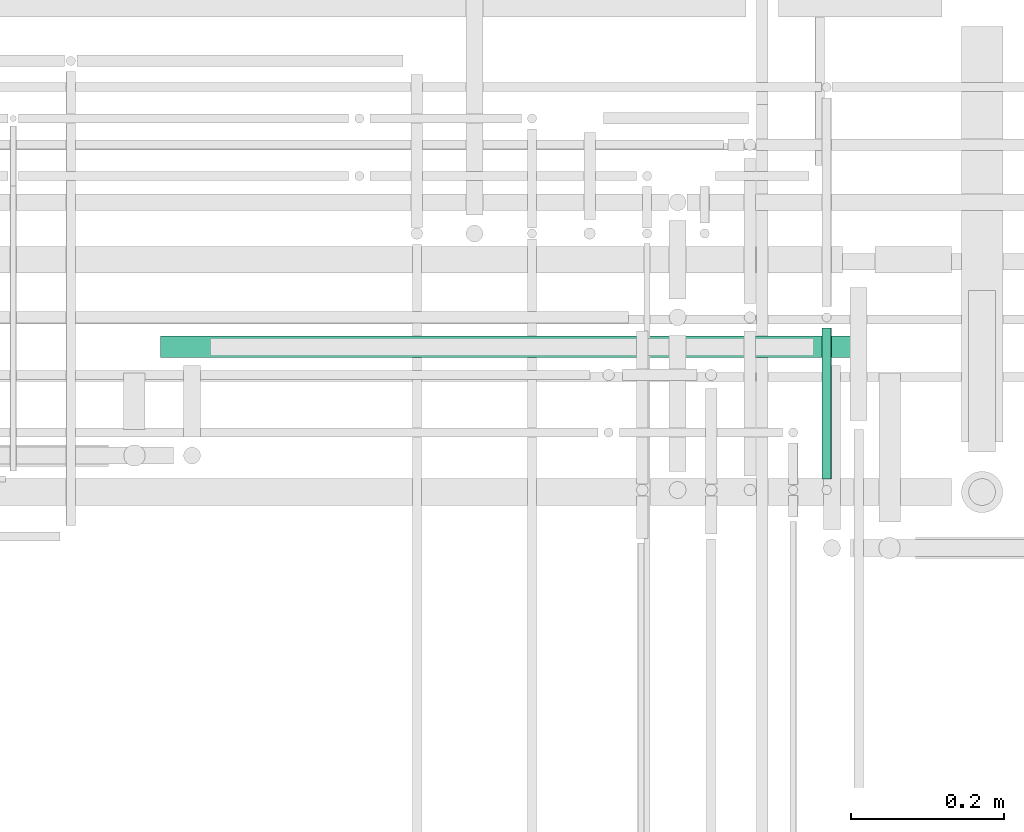
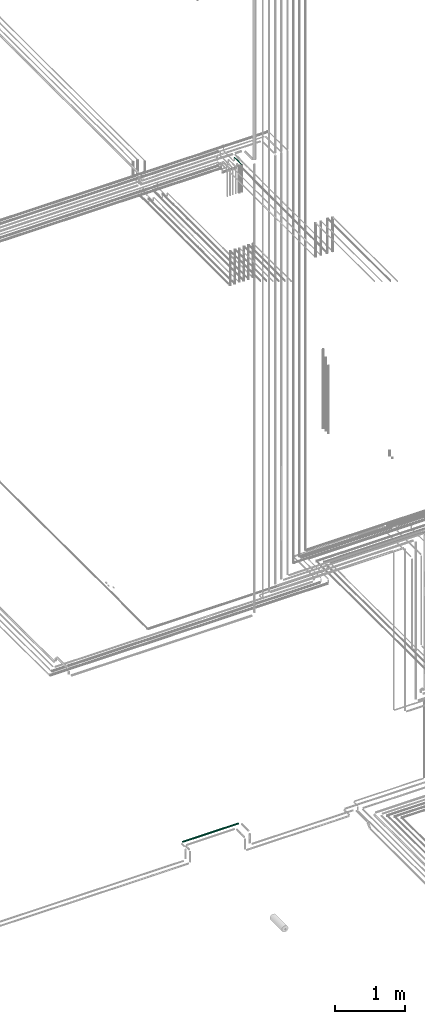
# One storey, part 221 of 331: 2 flow segments.
"""IFC2X3 building model written with IfcOpenShell, lengths in millimetres."""

from ifc_helpers import new_model, entity, si_unit, converted_unit, derived_unit, direction, frame, frame_2d, origin, origin_2d_with_axis, place, context, subcontext, project, spatial, circle, extrude, type_object, element, save


model = new_model("IFC2X3")

# Units and contexts
model_context = context("Model", 3, precision=0.01, world=origin(), true_north=direction((6.12303176911189e-17, 1.0)))
body_context = subcontext(model_context, "Body", "Model", "MODEL_VIEW")
ifc_project = project(units=[si_unit("LENGTHUNIT", "METRE", prefix="MILLI"), si_unit("AREAUNIT", "SQUARE_METRE"), si_unit("VOLUMEUNIT", "CUBIC_METRE"), converted_unit("PLANEANGLEUNIT", "DEGREE", entity("IfcRatioMeasure", 0.0174532925199433), si_unit("PLANEANGLEUNIT", "RADIAN"), dimensions=[0, 0, 0, 0, 0, 0, 0]), si_unit("MASSUNIT", "GRAM", prefix="KILO"), derived_unit("MASSDENSITYUNIT", [(si_unit("MASSUNIT", "GRAM", prefix="KILO"), 1), (si_unit("LENGTHUNIT", "METRE"), -3)]), derived_unit("MOMENTOFINERTIAUNIT", [(si_unit("LENGTHUNIT", "METRE"), 4)]), si_unit("TIMEUNIT", "SECOND"), si_unit("FREQUENCYUNIT", "HERTZ"), si_unit("THERMODYNAMICTEMPERATUREUNIT", "DEGREE_CELSIUS"), derived_unit("THERMALTRANSMITTANCEUNIT", [(si_unit("MASSUNIT", "GRAM", prefix="KILO"), 1), (si_unit("THERMODYNAMICTEMPERATUREUNIT", "KELVIN"), -1), (si_unit("TIMEUNIT", "SECOND"), -3)]), derived_unit("VOLUMETRICFLOWRATEUNIT", [(si_unit("LENGTHUNIT", "METRE"), 3), (si_unit("TIMEUNIT", "SECOND"), -1)]), derived_unit("MASSFLOWRATEUNIT", [(si_unit("MASSUNIT", "GRAM", prefix="KILO"), 1), (si_unit("TIMEUNIT", "SECOND"), -1)]), derived_unit("ROTATIONALFREQUENCYUNIT", [(si_unit("TIMEUNIT", "SECOND"), -1)]), si_unit("ELECTRICCURRENTUNIT", "AMPERE"), si_unit("ELECTRICVOLTAGEUNIT", "VOLT"), si_unit("POWERUNIT", "WATT"), si_unit("FORCEUNIT", "NEWTON", prefix="KILO"), si_unit("ILLUMINANCEUNIT", "LUX"), si_unit("LUMINOUSFLUXUNIT", "LUMEN"), si_unit("LUMINOUSINTENSITYUNIT", "CANDELA"), derived_unit("USERDEFINED", [(si_unit("MASSUNIT", "GRAM", prefix="KILO"), -1), (si_unit("LENGTHUNIT", "METRE"), -2), (si_unit("TIMEUNIT", "SECOND"), 3), (si_unit("LUMINOUSFLUXUNIT", "LUMEN"), 1)]), derived_unit("LINEARVELOCITYUNIT", [(si_unit("LENGTHUNIT", "METRE"), 1), (si_unit("TIMEUNIT", "SECOND"), -1)]), si_unit("PRESSUREUNIT", "PASCAL"), derived_unit("USERDEFINED", [(si_unit("LENGTHUNIT", "METRE"), -2), (si_unit("MASSUNIT", "GRAM", prefix="KILO"), 1), (si_unit("TIMEUNIT", "SECOND"), -2)]), derived_unit("LINEARFORCEUNIT", [(si_unit("MASSUNIT", "GRAM", prefix="KILO"), 1), (si_unit("LENGTHUNIT", "METRE"), 1), (si_unit("TIMEUNIT", "SECOND"), -2), (si_unit("LENGTHUNIT", "METRE"), -1)]), derived_unit("PLANARFORCEUNIT", [(si_unit("MASSUNIT", "GRAM", prefix="KILO"), 1), (si_unit("LENGTHUNIT", "METRE"), 1), (si_unit("TIMEUNIT", "SECOND"), -2), (si_unit("LENGTHUNIT", "METRE"), -2)])], contexts=[model_context])

# Site, building, storey
site_placement = place(None, frame((0.0, -0.00077364408347762, 0.0)))
site = spatial("IfcSite", under=ifc_project, at=site_placement, CompositionType="ELEMENT")
building_placement = place(site_placement, origin())
building = spatial("IfcBuilding", under=site, at=building_placement, CompositionType="ELEMENT")
storey_placement = place(building_placement, origin())
storey = spatial("IfcBuildingStorey", under=building, at=storey_placement, CompositionType="ELEMENT", Elevation=0.0)

# Flow segments
pipe_segment_type = type_object("IfcPipeSegmentType", PredefinedType="NOTDEFINED")
flow_segment_1_placement = place(building_placement, frame((62641.9979617591, 8321.40549070351, 2979.40472776409)))
element("IfcFlowSegment", 1, at=flow_segment_1_placement, inside=storey, type_object=pipe_segment_type, context=body_context, shape_type="SweptSolid", body=[
    extrude(circle(Radius=14.0, at=origin_2d_with_axis()), frame((0.0, 15.595272235916, 15.595272235916), z_axis=(1.0, 0.0, 0.0), x_axis=(0.0, 1.0, 0.0)), (0.0, 0.0, 1.0), 915.997558593767),
])
flow_segment_2_placement = place(storey_placement, frame((63502.5166110417, 8164.62056382735, 14542.4047277641)))
element("IfcFlowSegment", 2, at=flow_segment_2_placement, inside=storey, type_object=pipe_segment_type, context=body_context, shape_type="SweptSolid", body=[
    extrude(circle(Radius=6.0, at=frame_2d((0.0, -2.16573425859679e-12), x_axis=(1.0, 0.0))), frame((7.59527223591454, 0.0, 7.59527223591887), z_axis=(0.0, 1.0, 0.0), x_axis=(-1.0, 0.0, 0.0)), (0.0, 0.0, 1.0), 197.000000000019),
])

save(model, "model.ifc")
